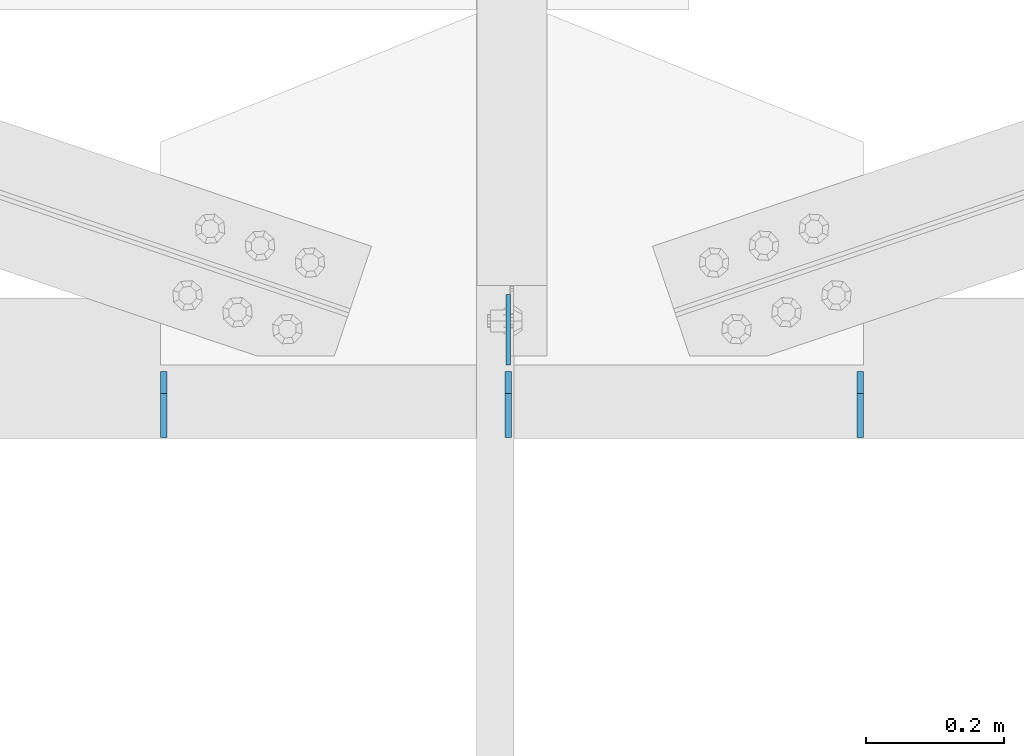
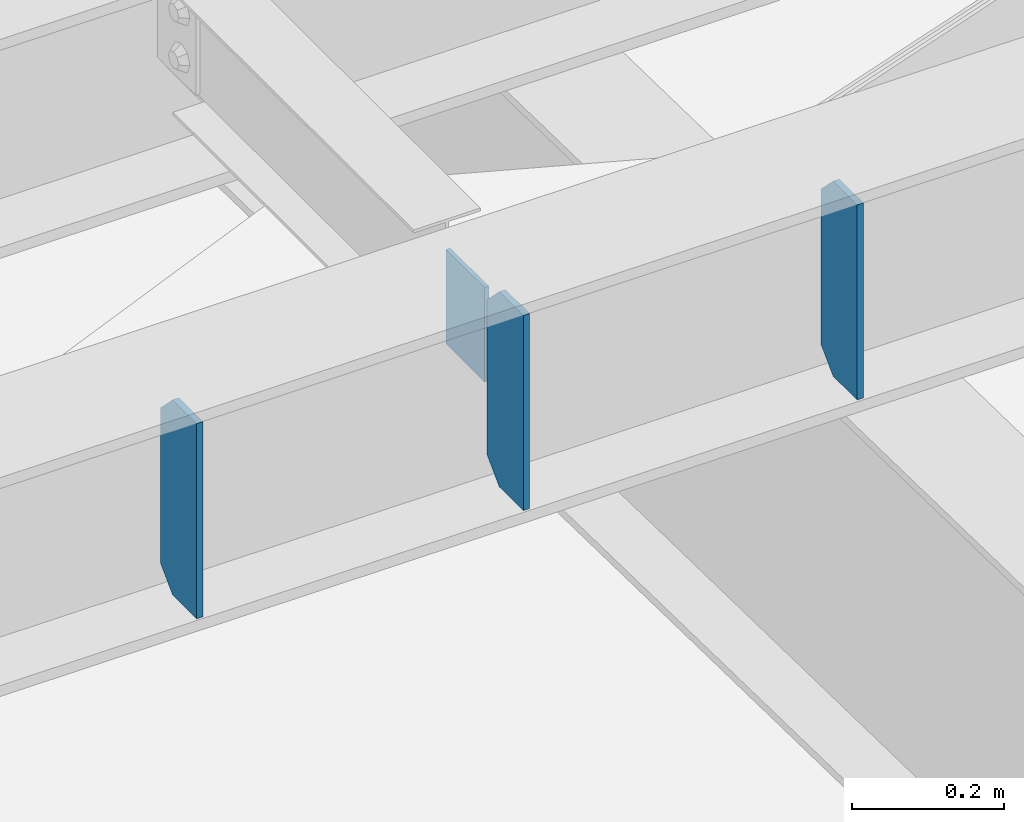
# One storey, part 1446 of 1763: 4 plates, 1 element without a shape of its own.
"""IFC2X3 building model written with IfcOpenShell, lengths in millimetres."""

from ifc_helpers import new_model, si_unit, frame, origin_with_axes, place, context, subcontext, project, spatial, faceted_brep, material, type_object, element, aggregate, save


model = new_model("IFC2X3")

# Units and contexts
model_context = context("Model", 3, precision=1e-05, world=origin_with_axes())
body_context = subcontext(model_context, "Body", "Model", "MODEL_VIEW")
ifc_project = project(units=[si_unit("LENGTHUNIT", "METRE", prefix="MILLI"), si_unit("AREAUNIT", "SQUARE_METRE"), si_unit("VOLUMEUNIT", "CUBIC_METRE"), si_unit("MASSUNIT", "GRAM", prefix="KILO"), si_unit("TIMEUNIT", "SECOND"), si_unit("PLANEANGLEUNIT", "RADIAN"), si_unit("SOLIDANGLEUNIT", "STERADIAN"), si_unit("THERMODYNAMICTEMPERATUREUNIT", "DEGREE_CELSIUS"), si_unit("LUMINOUSINTENSITYUNIT", "LUMEN")], contexts=[model_context])

# Site, building, storey
site_placement = place(None, origin_with_axes())
site = spatial("IfcSite", under=ifc_project, at=site_placement, CompositionType="ELEMENT")
building_placement = place(site_placement, origin_with_axes())
building = spatial("IfcBuilding", under=site, at=building_placement, Name="Undefined", CompositionType="ELEMENT")
storey_placement = place(building_placement, origin_with_axes())
storey = spatial("IfcBuildingStorey", under=building, at=storey_placement, Name="Undefined", CompositionType="ELEMENT", Elevation=0.0)

# Assembly, plates
assembly_placement = place(storey_placement, origin_with_axes())
assembly = element("IfcElementAssembly", 1, at=assembly_placement, inside=storey, Name="BEAM", AssemblyPlace="NOTDEFINED", PredefinedType="RIGID_FRAME")
ifc_material = material(Name="STEEL/A36")
plate_type_1 = type_object("IfcPlateType", PredefinedType="NOTDEFINED")
plate_1_placement = place(assembly_placement, frame((-60636.9007757594, -15447.9645340402, 18783.3), z_axis=(-6.21520000058808e-05, 0.999999998068564, 0.0), x_axis=(0.0, 0.0, -1.0)))
plate_1 = element("IfcPlate", 2, at=plate_1_placement, type_object=plate_type_1, material=ifc_material, Name="PLATE", context=body_context, shape_type="Brep", body=[
    faceted_brep([(1.81898940354586e-12, -3.17500000000291, 0.0), (0.0, -3.17499999999927, 101.599998474121), (0.0, 3.17499999999927, 101.599998474121), (-1.81898940354586e-12, 3.17499999997381, 0.0), (152.399993896484, -3.17499999999927, 101.599998474121), (152.399993896484, 3.17499999999927, 101.599998474121), (152.399993896484, -3.17500000000291, 0.0), (152.399993896484, 3.17500000000291, 0.0)], [[[0, 1, 2, 3]], [[1, 4, 5, 2]], [[4, 6, 7, 5]], [[6, 0, 3, 7]], [[5, 7, 3, 2]], [[6, 4, 1, 0]]]),
])
plate_type_2 = type_object("IfcPlateType", PredefinedType="NOTDEFINED")
plate_2_placement = place(assembly_placement, frame((-61134.6132616129, -15552.7397284022, 18488.025), z_axis=(0.0, 0.0, 1.0), x_axis=(0.0, 1.0, 0.0)))
plate_2 = element("IfcPlate", 3, at=plate_2_placement, type_object=plate_type_2, material=ifc_material, Name="PLATE", context=body_context, shape_type="Brep", body=[
    faceted_brep([(0.0, -4.76249999999982, 0.0), (-7.27595761418343e-12, -4.76250000000073, 314.325000762939), (7.27595761418343e-12, 4.76250000000437, 314.325000762939), (0.0, 4.76249999999982, 0.0), (63.4999999999964, -4.76250000017171, 314.325012207031), (63.5000000000036, 4.76249999982974, 314.325012207031), (95.2499999999964, -4.76250000025902, 282.575012207031), (95.2500000000036, 4.76249999974243, 282.575012207031), (95.2499999999964, -4.76250000025902, 31.75), (95.2500000000036, 4.76249999974243, 31.75), (63.4999999999964, -4.76250000017171, 0.0), (63.5000000000036, 4.76249999982974, 0.0)], [[[0, 1, 2, 3]], [[1, 4, 5, 2]], [[4, 6, 7, 5]], [[6, 8, 9, 7]], [[8, 10, 11, 9]], [[10, 0, 3, 11]], [[5, 7, 9, 11, 3, 2]], [[10, 8, 6, 4, 1, 0]]]),
])
plate_3_placement = place(assembly_placement, frame((-60636.9007763885, -15552.7397313885, 18488.025), z_axis=(0.0, 0.0, 1.0), x_axis=(0.0, 1.0, 0.0)))
plate_3 = element("IfcPlate", 4, at=plate_3_placement, type_object=plate_type_2, material=ifc_material, Name="PLATE", context=body_context, shape_type="Brep", body=[
    faceted_brep([(0.0, -4.76249999999982, 0.0), (-7.27595761418343e-12, -4.76250000000073, 314.325000762939), (7.27595761418343e-12, 4.76250000000437, 314.325000762939), (0.0, 4.76249999999982, 0.0), (63.4999999999964, -4.76250000017171, 314.325012207031), (63.5000000000036, 4.76249999982974, 314.325012207031), (95.2499999999964, -4.76250000025902, 282.575012207031), (95.2500000000036, 4.76249999974243, 282.575012207031), (95.2499999999964, -4.76250000025902, 31.75), (95.2500000000036, 4.76249999974243, 31.75), (63.4999999999964, -4.76250000017171, 0.0), (63.5000000000036, 4.76249999982974, 0.0)], [[[0, 1, 2, 3]], [[1, 4, 5, 2]], [[4, 6, 7, 5]], [[6, 8, 9, 7]], [[8, 10, 11, 9]], [[10, 0, 3, 11]], [[5, 7, 9, 11, 3, 2]], [[10, 8, 6, 4, 1, 0]]]),
])
plate_4_placement = place(assembly_placement, frame((-60128.1382616131, -15552.739734441, 18488.025), z_axis=(0.0, 0.0, 1.0), x_axis=(0.0, 1.0, 0.0)))
plate_4 = element("IfcPlate", 5, at=plate_4_placement, type_object=plate_type_2, material=ifc_material, Name="PLATE", context=body_context, shape_type="Brep", body=[
    faceted_brep([(0.0, -4.76249999999982, 0.0), (-7.27595761418343e-12, -4.76250000000073, 314.325000762939), (7.27595761418343e-12, 4.76250000000437, 314.325000762939), (0.0, 4.76249999999982, 0.0), (63.4999999999964, -4.76250000017171, 314.325012207031), (63.5000000000036, 4.76249999982974, 314.325012207031), (95.2499999999964, -4.76250000025902, 282.575012207031), (95.2500000000036, 4.76249999974243, 282.575012207031), (95.2499999999964, -4.76250000025902, 31.75), (95.2500000000036, 4.76249999974243, 31.75), (63.4999999999964, -4.76250000017171, 0.0), (63.5000000000036, 4.76249999982974, 0.0)], [[[0, 1, 2, 3]], [[1, 4, 5, 2]], [[4, 6, 7, 5]], [[6, 8, 9, 7]], [[8, 10, 11, 9]], [[10, 0, 3, 11]], [[5, 7, 9, 11, 3, 2]], [[10, 8, 6, 4, 1, 0]]]),
])
aggregate(assembly, [plate_2, plate_3, plate_4, plate_1])

save(model, "model.ifc")
